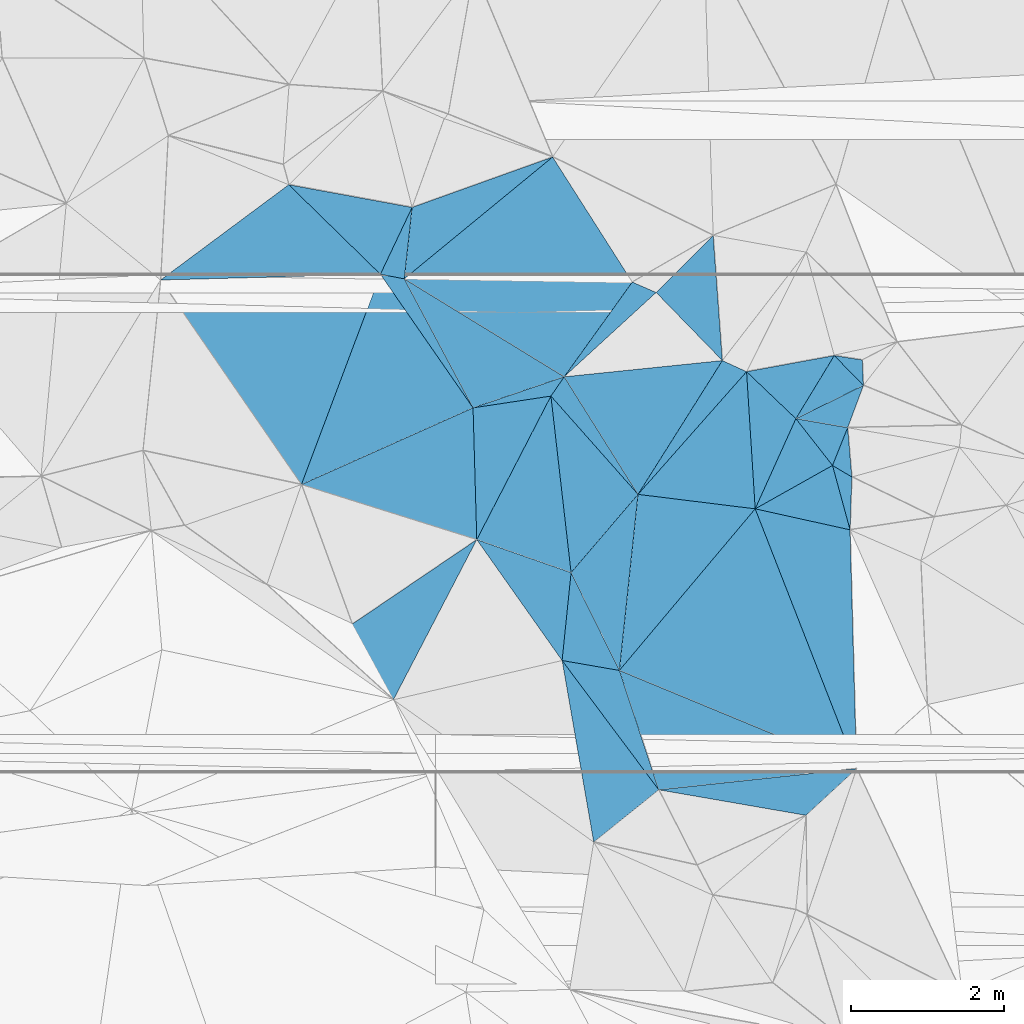
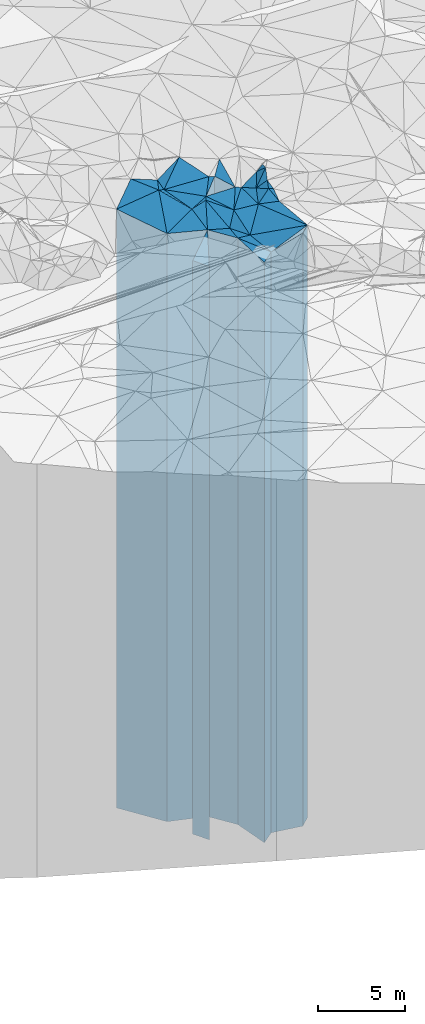
# One storey, part 205 of 275: 42 plates.
"""IFC2X3 building model written with IfcOpenShell, lengths in millimetres."""

from ifc_helpers import new_model, si_unit, frame, origin_with_axes, place, context, subcontext, project, spatial, faceted_brep, material, type_object, element, save


model = new_model("IFC2X3")

# Units and contexts
model_context = context("Model", 3, precision=1e-05, world=origin_with_axes())
body_context = subcontext(model_context, "Body", "Model", "MODEL_VIEW")
ifc_project = project(units=[si_unit("LENGTHUNIT", "METRE", prefix="MILLI"), si_unit("AREAUNIT", "SQUARE_METRE"), si_unit("VOLUMEUNIT", "CUBIC_METRE"), si_unit("MASSUNIT", "GRAM", prefix="KILO"), si_unit("TIMEUNIT", "SECOND"), si_unit("PLANEANGLEUNIT", "RADIAN"), si_unit("SOLIDANGLEUNIT", "STERADIAN"), si_unit("THERMODYNAMICTEMPERATUREUNIT", "DEGREE_CELSIUS"), si_unit("LUMINOUSINTENSITYUNIT", "LUMEN")], contexts=[model_context])

# Site, building, storey
site_placement = place(None, origin_with_axes())
site = spatial("IfcSite", under=ifc_project, at=site_placement, CompositionType="ELEMENT")
building_placement = place(site_placement, origin_with_axes())
building = spatial("IfcBuilding", under=site, at=building_placement, Name="Undefined", CompositionType="ELEMENT")
storey_placement = place(building_placement, origin_with_axes())
storey = spatial("IfcBuildingStorey", under=building, at=storey_placement, Name="Undefined", CompositionType="ELEMENT", Elevation=0.0)

# Plates
ifc_material = material()
plate_type_1 = type_object("IfcPlateType", PredefinedType="NOTDEFINED")
plate_1_placement = place(storey_placement, frame((-119183.131620389, 61506.4267955561, 28304.0), z_axis=(0.985184457035892, 0.171498063006248, 0.0), x_axis=(0.171498063006245, -0.985184457035892, 0.0)))
element("IfcPlate", 1, at=plate_1_placement, inside=storey, type_object=plate_type_1, material=ifc_material, Name="00", context=body_context, shape_type="Brep", body=[
    faceted_brep([(0.0, -20916.0, 0.0), (1875.76220703125, -20516.0, 951.270812988281), (1875.76220703125, 20476.0, 951.270812988281), (0.0, 20476.0, 0.0), (2401.10400390624, -20476.0, -1.12049747258425e-09), (2401.10400390624, 20476.0, -1.12049747258425e-09)], [[[0, 1, 2, 3]], [[1, 4, 5, 2]], [[4, 0, 3, 5]], [[5, 3, 2]], [[4, 1, 0]]]),
])
plate_type_2 = type_object("IfcPlateType", PredefinedType="NOTDEFINED")
plate_2_placement = place(storey_placement, frame((-117924.26484308, 59821.5961105942, 28324.0), z_axis=(-0.949714789561754, -0.313116301855515, 0.0), x_axis=(-0.313116301855509, 0.949714789561756, 0.0)))
element("IfcPlate", 2, at=plate_2_placement, inside=storey, type_object=plate_type_2, material=ifc_material, Name="00", context=body_context, shape_type="Brep", body=[
    faceted_brep([(2.91038304567337e-11, -20496.0, 2.91038304567337e-11), (1994.28027343753, -20896.0, 668.016418457046), (1994.28027343753, 20496.0, 668.016418457046), (2.91038304567337e-11, 20496.0, 2.91038304567337e-11), (1637.83398437503, -20916.0, -3.28873284161091e-09), (1637.83398437503, 20496.0, -3.28873284161091e-09)], [[[0, 1, 2, 3]], [[1, 4, 5, 2]], [[4, 0, 3, 5]], [[5, 3, 2]], [[4, 1, 0]]]),
])
plate_type_3 = type_object("IfcPlateType", PredefinedType="NOTDEFINED")
plate_3_placement = place(storey_placement, frame((-119183.131620389, 61506.4267955561, 28499.0), z_axis=(0.170841814937065, 0.985298469636998, 0.0), x_axis=(0.985298469637004, -0.17084181493703, 0.0)))
element("IfcPlate", 3, at=plate_3_placement, inside=storey, type_object=plate_type_3, material=ifc_material, Name="00", context=body_context, shape_type="Brep", body=[
    faceted_brep([(1.45519152283669e-11, -20721.0, 0.0), (-80.431526184082, -20671.0, 1148.22937011719), (-80.431526184082, 20671.0, 1148.22937011719), (1.45519152283669e-11, 20671.0, 0.0), (757.16577148439, -20741.0, -2.895831130445e-09), (757.16577148439, 20671.0, -2.895831130445e-09)], [[[0, 1, 2, 3]], [[1, 4, 5, 2]], [[4, 0, 3, 5]], [[5, 3, 2]], [[4, 1, 0]]]),
])
plate_type_4 = type_object("IfcPlateType", PredefinedType="NOTDEFINED")
plate_4_placement = place(storey_placement, frame((-118194.118442681, 63671.2946747395, 28499.0), z_axis=(0.759992196008356, -0.649932198007143, 0.0), x_axis=(-0.649932198007148, -0.759992196008352, 0.0)))
element("IfcPlate", 4, at=plate_4_placement, inside=storey, type_object=plate_type_4, material=ifc_material, Name="00", context=body_context, shape_type="Brep", body=[
    faceted_brep([(-7.27595761418343e-12, -21041.0, -2.91038304567337e-11), (1901.51171875001, -20741.0, 1306.42761230466), (1901.51171875001, 20671.0, 1306.42761230466), (1.45519152283669e-11, 20671.0, 0.0), (1341.82714843749, -20671.0, 1.45519152283669e-10), (1341.82714843749, 20671.0, 1.45519152283669e-10)], [[[0, 1, 2, 3]], [[1, 4, 5, 2]], [[4, 0, 3, 5]], [[5, 3, 2]], [[4, 1, 0]]]),
])
plate_type_5 = type_object("IfcPlateType", PredefinedType="NOTDEFINED")
plate_5_placement = place(storey_placement, frame((-115345.769629533, 60097.9336464306, 28324.0), z_axis=(-0.382343494971792, -0.924020265931844, 0.0), x_axis=(-0.924020265931842, 0.382343494971797, 0.0)))
element("IfcPlate", 5, at=plate_5_placement, inside=storey, type_object=plate_type_5, material=ifc_material, Name="00", context=body_context, shape_type="Brep", body=[
    faceted_brep([(0.0, -21316.0, -7.27595761418343e-12), (2276.92602539064, -20496.0, 1241.21240234374), (2276.92602539064, 20496.0, 1241.21240234374), (2.91038304567337e-11, 20496.0, 2.91038304567337e-11), (3345.51928710939, -20916.0, 6.91943569108844e-09), (3345.51928710939, 20496.0, 6.91943569108844e-09)], [[[0, 1, 2, 3]], [[1, 4, 5, 2]], [[4, 0, 3, 5]], [[5, 3, 2]], [[4, 1, 0]]]),
])
plate_type_6 = type_object("IfcPlateType", PredefinedType="NOTDEFINED")
plate_6_placement = place(storey_placement, frame((-118437.09734801, 61377.0712218987, 28534.0), z_axis=(-0.765511761828982, 0.643421900856264, 0.0), x_axis=(0.643421900856258, 0.765511761828987, 0.0)))
element("IfcPlate", 6, at=plate_6_placement, inside=storey, type_object=plate_type_6, material=ifc_material, Name="00", context=body_context, shape_type="Brep", body=[
    faceted_brep([(-7.27595761418343e-12, -20706.0, -1.45519152283669e-11), (1912.59301757814, -21006.0, 1290.150390625), (1912.59301757814, 20706.0, 1290.150390625), (2.18278728425503e-11, 20706.0, 0.0), (2750.45458984377, -21006.0, 3.47790773957968e-09), (2750.45458984377, 20706.0, 3.47790773957968e-09)], [[[0, 1, 2, 3]], [[1, 4, 5, 2]], [[4, 0, 3, 5]], [[5, 3, 2]], [[4, 1, 0]]]),
])
plate_type_7 = type_object("IfcPlateType", PredefinedType="NOTDEFINED")
plate_7_placement = place(storey_placement, frame((-119328.867979049, 64951.7803207788, 28499.0), z_axis=(0.888482110108516, -0.45891125505605, 0.0), x_axis=(-0.458911255056047, -0.888482110108517, 0.0)))
element("IfcPlate", 7, at=plate_7_placement, inside=storey, type_object=plate_type_7, material=ifc_material, Name="00", context=body_context, shape_type="Brep", body=[
    faceted_brep([(0.0, -21351.0, 0.0), (1923.20886230468, -20671.0, 1288.97937011722), (1923.20886230468, 20671.0, 1288.97937011722), (1.45519152283669e-11, 20671.0, 0.0), (2105.23168945311, -20731.0, 9.19681042432785e-09), (2105.23168945311, 20671.0, 9.19681042432785e-09)], [[[0, 1, 2, 3]], [[1, 4, 5, 2]], [[4, 0, 3, 5]], [[5, 3, 2]], [[4, 1, 0]]]),
])
plate_type_8 = type_object("IfcPlateType", PredefinedType="NOTDEFINED")
plate_8_placement = place(storey_placement, frame((-115462.191569399, 64540.3030515924, 28874.0), z_axis=(0.927767243245815, -0.373159406098871, 0.0), x_axis=(-0.373159406098872, -0.927767243245814, 0.0)))
element("IfcPlate", 8, at=plate_8_placement, inside=storey, type_object=plate_type_8, material=ifc_material, Name="00", context=body_context, shape_type="Brep", body=[
    faceted_brep([(3.63797880709171e-12, -21286.0, 0.0), (576.005126953121, -21046.0, 290.547912597642), (576.005126953121, 21046.0, 290.547912597642), (3.63797880709171e-12, 21046.0, 0.0), (530.377197265621, -21066.0, 1.94995664060116e-09), (530.377197265621, 21046.0, 1.94995664060116e-09)], [[[0, 1, 2, 3]], [[1, 4, 5, 2]], [[4, 0, 3, 5]], [[5, 3, 2]], [[4, 1, 0]]]),
])
plate_type_9 = type_object("IfcPlateType", PredefinedType="NOTDEFINED")
plate_9_placement = place(storey_placement, frame((-115407.572455855, 63897.4836738231, 28649.0), z_axis=(-0.512574769797824, -0.858642594661311, 0.0), x_axis=(-0.858642594661316, 0.512574769797815, 0.0)))
element("IfcPlate", 9, at=plate_9_placement, inside=storey, type_object=plate_type_9, material=ifc_material, Name="00", context=body_context, shape_type="Brep", body=[
    faceted_brep([(0.0, -21271.0, 7.27595761418343e-12), (-332.529968261719, -20821.0, 603.178100585945), (-332.529968261719, 20821.0, 603.178100585945), (0.0, 20821.0, 7.27595761418343e-12), (294.108825683594, -21291.0, -1.50612322613597e-09), (294.108825683594, 20821.0, -1.50612322613597e-09)], [[[0, 1, 2, 3]], [[1, 4, 5, 2]], [[4, 0, 3, 5]], [[5, 3, 2]], [[4, 1, 0]]]),
])
plate_type_10 = type_object("IfcPlateType", PredefinedType="NOTDEFINED")
plate_10_placement = place(storey_placement, frame((-119155.779576503, 65203.2567707775, 28749.0), z_axis=(-0.522218806266238, -0.852811537434775, 0.0), x_axis=(-0.852811537434775, 0.522218806266238, 0.0)))
element("IfcPlate", 10, at=plate_10_placement, inside=storey, type_object=plate_type_10, material=ifc_material, Name="00", context=body_context, shape_type="Brep", body=[
    faceted_brep([(0.0, -21161.0, 2.72848410531878e-12), (801.453979492188, -20921.0, 965.542114257808), (801.453979492188, 20921.0, 965.542114257808), (0.0, 20921.0, 2.72848410531878e-12), (2443.80859375, -21591.0, 1.97451299754903e-09), (2443.80859375, 20921.0, 1.97451299754903e-09)], [[[0, 1, 2, 3]], [[1, 4, 5, 2]], [[4, 0, 3, 5]], [[5, 3, 2]], [[4, 1, 0]]]),
])
plate_type_11 = type_object("IfcPlateType", PredefinedType="NOTDEFINED")
plate_11_placement = place(storey_placement, frame((-121550.470798273, 66538.9415960164, 28579.0), z_axis=(0.936101686798957, -0.351729486924464, 0.0), x_axis=(-0.351729486924462, -0.936101686798958, 0.0)))
element("IfcPlate", 11, at=plate_11_placement, inside=storey, type_object=plate_type_11, material=ifc_material, Name="00", context=body_context, shape_type="Brep", body=[
    faceted_brep([(0.0, -21801.0, 0.0), (1204.82641601563, -21091.0, 1742.06579589844), (1204.82641601563, 20751.0, 1742.06579589844), (0.0, 20751.0, 0.0), (2927.55859375, -20751.0, 2.09547579288483e-08), (2927.55859375, 20751.0, 2.09547579288483e-08)], [[[0, 1, 2, 3]], [[1, 4, 5, 2]], [[4, 0, 3, 5]], [[5, 3, 2]], [[4, 1, 0]]]),
])
plate_type_12 = type_object("IfcPlateType", PredefinedType="NOTDEFINED")
plate_12_placement = place(storey_placement, frame((-119155.779576503, 65203.2567707775, 28869.0), z_axis=(-0.812080748612463, 0.583545077721526, 0.0), x_axis=(0.583545077721523, 0.812080748612465, 0.0)))
element("IfcPlate", 12, at=plate_12_placement, inside=storey, type_object=plate_type_12, material=ifc_material, Name="00", context=body_context, shape_type="Brep", body=[
    faceted_brep([(-7.27595761418343e-12, -21041.0, -2.91038304567337e-11), (-179.791320800774, -21471.0, 2437.18579101563), (-179.791320800774, 21041.0, 2437.18579101563), (2.18278728425503e-11, 21041.0, 0.0), (1519.53942871095, -21371.0, -2.3283064365387e-10), (1519.53942871095, 21041.0, -2.3283064365387e-10)], [[[0, 1, 2, 3]], [[1, 4, 5, 2]], [[4, 0, 3, 5]], [[5, 3, 2]], [[4, 1, 0]]]),
])
plate_type_13 = type_object("IfcPlateType", PredefinedType="NOTDEFINED")
plate_13_placement = place(storey_placement, frame((-120343.493003675, 64798.3656558902, 28749.0), z_axis=(-0.149503958020634, 0.988761127136461, 0.0), x_axis=(0.988761127136461, 0.149503958020635, 0.0)))
element("IfcPlate", 13, at=plate_13_placement, inside=storey, type_object=plate_type_13, material=ifc_material, Name="00", context=body_context, shape_type="Brep", body=[
    faceted_brep([(0.0, -20921.0, 0.0), (1234.89770507814, -21161.0, 222.772735595703), (1234.89770507814, 20921.0, 222.772735595703), (0.0, 20921.0, 2.72848410531878e-12), (1026.15783691408, -21101.0, 1.76078174263239e-09), (1026.15783691408, 20921.0, 1.76078174263239e-09)], [[[0, 1, 2, 3]], [[1, 4, 5, 2]], [[4, 0, 3, 5]], [[5, 3, 2]], [[4, 1, 0]]]),
])
plate_type_14 = type_object("IfcPlateType", PredefinedType="NOTDEFINED")
plate_14_placement = place(storey_placement, frame((-115637.071651429, 65479.8332304102, 28749.0), z_axis=(0.180778557086176, -0.983523824468854, 0.0), x_axis=(-0.983523824468853, -0.180778557086182, 0.0)))
element("IfcPlate", 14, at=plate_14_placement, inside=storey, type_object=plate_type_14, material=ifc_material, Name="00", context=body_context, shape_type="Brep", body=[
    faceted_brep([(0.0, -21501.0, -1.45519152283669e-11), (640.552856445313, -21011.0, 718.534667968721), (640.552856445313, 20921.0, 718.534667968721), (0.0, 20921.0, 2.72848410531878e-12), (1161.80895996095, -20921.0, 3.41970007866621e-09), (1161.80895996095, 20921.0, 3.41970007866621e-09)], [[[0, 1, 2, 3]], [[1, 4, 5, 2]], [[4, 0, 3, 5]], [[5, 3, 2]], [[4, 1, 0]]]),
])
plate_type_15 = type_object("IfcPlateType", PredefinedType="NOTDEFINED")
plate_15_placement = place(storey_placement, frame((-116667.39467936, 63482.5764972598, 28684.0), z_axis=(-0.489643351877605, 0.871922810782046, 0.0), x_axis=(0.871922810782047, 0.489643351877604, 0.0)))
element("IfcPlate", 15, at=plate_15_placement, inside=storey, type_object=plate_type_15, material=ifc_material, Name="00", context=body_context, shape_type="Brep", body=[
    faceted_brep([(-1.45519152283669e-11, -20856.0, 0.0), (1037.52539062499, -21076.0, 764.683715820313), (1037.52539062499, 20856.0, 764.683715820313), (-1.45519152283669e-11, 20856.0, 0.0), (1155.24890136719, -21256.0, -2.8521753847599e-09), (1155.24890136719, 20856.0, -2.8521753847599e-09)], [[[0, 1, 2, 3]], [[1, 4, 5, 2]], [[4, 0, 3, 5]], [[5, 3, 2]], [[4, 1, 0]]]),
])
plate_type_16 = type_object("IfcPlateType", PredefinedType="NOTDEFINED")
plate_16_placement = place(storey_placement, frame((-116137.174958694, 64657.3390468063, 28794.0), z_axis=(0.787267103683257, 0.616612120751916, 0.0), x_axis=(0.616612120751918, -0.787267103683255, 0.0)))
element("IfcPlate", 16, at=plate_16_placement, inside=storey, type_object=plate_type_16, material=ifc_material, Name="00", context=body_context, shape_type="Brep", body=[
    faceted_brep([(2.91038304567337e-11, -20966.0, 1.45519152283669e-11), (508.341522216797, -21366.0, 459.226409912117), (508.341522216797, 20966.0, 459.226409912117), (2.91038304567337e-11, 20966.0, 1.45519152283669e-11), (773.692443847656, -21146.0, 1.5788828022778e-09), (773.692443847656, 20966.0, 1.5788828022778e-09)], [[[0, 1, 2, 3]], [[1, 4, 5, 2]], [[4, 0, 3, 5]], [[5, 3, 2]], [[4, 1, 0]]]),
])
plate_type_17 = type_object("IfcPlateType", PredefinedType="NOTDEFINED")
plate_17_placement = place(storey_placement, frame((-121137.59422499, 67410.3387128543, 29104.0), z_axis=(-0.180869426929462, -0.983507117616445, 0.0), x_axis=(-0.983507117616445, 0.180869426929464, 0.0)))
element("IfcPlate", 17, at=plate_17_placement, inside=storey, type_object=plate_type_17, material=ifc_material, Name="00", context=body_context, shape_type="Brep", body=[
    faceted_brep([(0.0, -21316.0, -7.27595761418343e-12), (248.457946777344, -21276.0, 931.70202636718), (248.457946777344, 21276.0, 931.70202636718), (0.0, 21276.0, 0.0), (1633.67687988281, -21776.0, -1.25583028420806e-08), (1633.67687988281, 21276.0, -1.25583028420806e-08)], [[[0, 1, 2, 3]], [[1, 4, 5, 2]], [[4, 0, 3, 5]], [[5, 3, 2]], [[4, 1, 0]]]),
])
plate_type_18 = type_object("IfcPlateType", PredefinedType="NOTDEFINED")
plate_18_placement = place(storey_placement, frame((-120343.493003675, 64798.3656558902, 28749.0), z_axis=(-0.882394073417891, -0.470511104222824, 0.0), x_axis=(-0.470511104222825, 0.882394073417891, 0.0)))
element("IfcPlate", 18, at=plate_18_placement, inside=storey, type_object=plate_type_18, material=ifc_material, Name="00", context=body_context, shape_type="Brep", body=[
    faceted_brep([(0.0, -20921.0, 0.0), (2103.77026367188, -21631.0, 246.069747924819), (2103.77026367188, 20921.0, 246.069747924819), (0.0, 20921.0, 2.72848410531878e-12), (1905.15087890625, -21591.0, 3.36149241775274e-09), (1905.15087890625, 20921.0, 3.36149241775274e-09)], [[[0, 1, 2, 3]], [[1, 4, 5, 2]], [[4, 0, 3, 5]], [[5, 3, 2]], [[4, 1, 0]]]),
])
plate_type_19 = type_object("IfcPlateType", PredefinedType="NOTDEFINED")
plate_19_placement = place(storey_placement, frame((-120294.982445827, 63081.3197258764, 28529.0), z_axis=(-0.888482110108516, 0.45891125505605, 0.0), x_axis=(0.458911255056051, 0.888482110108515, 0.0)))
element("IfcPlate", 19, at=plate_19_placement, inside=storey, type_object=plate_type_19, material=ifc_material, Name="00", context=body_context, shape_type="Brep", body=[
    faceted_brep([(9.54969436861575e-12, -20701.0, 0.0), (1503.30249023438, -21141.0, 831.072448730469), (1503.30249023438, 20701.0, 831.072448730469), (9.54969436861575e-12, 20701.0, 0.0), (2105.23168945313, -21321.0, 9.13860276341438e-09), (2105.23168945313, 20701.0, 9.13860276341438e-09)], [[[0, 1, 2, 3]], [[1, 4, 5, 2]], [[4, 0, 3, 5]], [[5, 3, 2]], [[4, 1, 0]]]),
])
plate_type_20 = type_object("IfcPlateType", PredefinedType="NOTDEFINED")
plate_20_placement = place(storey_placement, frame((-115257.058617225, 65090.2307485966, 29039.0), z_axis=(-0.998896409609664, -0.0469676789816477, 0.0), x_axis=(-0.0469676789816322, 0.998896409609664, 0.0)))
element("IfcPlate", 20, at=plate_20_placement, inside=storey, type_object=plate_type_20, material=ifc_material, Name="00", context=body_context, shape_type="Brep", body=[
    faceted_brep([(0.0, -21611.0, 1.45519152283669e-11), (407.020843505859, -21211.0, 361.294921875015), (407.020843505859, 21211.0, 361.294921875015), (0.0, 21211.0, 1.45519152283669e-11), (332.415405273438, -21641.0, 7.27595761418343e-11), (332.415405273438, 21211.0, 7.27595761418343e-11)], [[[0, 1, 2, 3]], [[1, 4, 5, 2]], [[4, 0, 3, 5]], [[5, 3, 2]], [[4, 1, 0]]]),
])
plate_type_21 = type_object("IfcPlateType", PredefinedType="NOTDEFINED")
plate_21_placement = place(storey_placement, frame((-116137.174958694, 64657.3390468063, 28794.0), z_axis=(0.170841814937065, 0.985298469636998, 0.0), x_axis=(0.985298469637004, -0.17084181493703, 0.0)))
element("IfcPlate", 21, at=plate_21_placement, inside=storey, type_object=plate_type_21, material=ifc_material, Name="00", context=body_context, shape_type="Brep", body=[
    faceted_brep([(2.91038304567337e-11, -20966.0, 1.45519152283669e-11), (793.221252441406, -21856.0, 576.888183593757), (793.221252441406, 20966.0, 576.888183593757), (2.91038304567337e-11, 20966.0, 1.45519152283669e-11), (685.054748535156, -21366.0, -2.60479282587767e-09), (685.054748535156, 20966.0, -2.60479282587767e-09)], [[[0, 1, 2, 3]], [[1, 4, 5, 2]], [[4, 0, 3, 5]], [[5, 3, 2]], [[4, 1, 0]]]),
])
plate_type_22 = type_object("IfcPlateType", PredefinedType="NOTDEFINED")
plate_22_placement = place(storey_placement, frame((-121550.470798273, 66538.9415960164, 29084.0), z_axis=(0.188098807986449, 0.98215010992927, 0.0), x_axis=(0.982150109929266, -0.188098807986467, 0.0)))
element("IfcPlate", 22, at=plate_22_placement, inside=storey, type_object=plate_type_22, material=ifc_material, Name="00", context=body_context, shape_type="Brep", body=[
    faceted_brep([(0.0, -21296.0, 1.45519152283669e-11), (241.598007202178, -21336.0, 933.504394531265), (241.598007202178, 21256.0, 933.504394531265), (0.0, 21256.0, 1.45519152283669e-11), (316.227752685547, -21256.0, 1.67347025126219e-09), (316.227752685547, 21256.0, 1.67347025126219e-09)], [[[0, 1, 2, 3]], [[1, 4, 5, 2]], [[4, 0, 3, 5]], [[5, 3, 2]], [[4, 1, 0]]]),
])
plate_type_23 = type_object("IfcPlateType", PredefinedType="NOTDEFINED")
plate_23_placement = place(storey_placement, frame((-117957.606478742, 66301.6106426251, 28869.0), z_axis=(-0.399271495028854, -0.91683274006627, 0.0), x_axis=(-0.916832740066265, 0.399271495028864, 0.0)))
element("IfcPlate", 23, at=plate_23_placement, inside=storey, type_object=plate_type_23, material=ifc_material, Name="00", context=body_context, shape_type="Brep", body=[
    faceted_brep([(-6.59383658785373e-12, -21371.0, 1.45519152283669e-11), (659.982910156279, -21041.0, 1485.40319824219), (659.982910156279, 21041.0, 1485.40319824219), (2.18278728425503e-11, 21041.0, 0.0), (339.705749511719, -21371.0, 2.37923813983798e-09), (339.705749511719, 21041.0, 2.37923813983798e-09)], [[[0, 1, 2, 3]], [[1, 4, 5, 2]], [[4, 0, 3, 5]], [[5, 3, 2]], [[4, 1, 0]]]),
])
plate_type_24 = type_object("IfcPlateType", PredefinedType="NOTDEFINED")
plate_24_placement = place(storey_placement, frame((-121239.887663094, 66479.4595302959, 29034.0), z_axis=(0.0142080939991206, 0.999899059938008, 0.0), x_axis=(0.999899059938008, -0.0142080939991182, 0.0)))
element("IfcPlate", 24, at=plate_24_placement, inside=storey, type_object=plate_type_24, material=ifc_material, Name="00", context=body_context, shape_type="Brep", body=[
    faceted_brep([(1.45519152283669e-11, -21306.0, 3.63797880709171e-12), (1910.45300292969, -21956.0, 1614.67309570312), (1910.45300292969, 21206.0, 1614.67309570312), (-1.45519152283669e-11, 21206.0, 0.0), (2971.12768554688, -21206.0, -1.64582161232829e-08), (2971.12768554688, 21206.0, -1.64582161232829e-08)], [[[0, 1, 2, 3]], [[1, 4, 5, 2]], [[4, 0, 3, 5]], [[5, 3, 2]], [[4, 1, 0]]]),
])
plate_type_25 = type_object("IfcPlateType", PredefinedType="NOTDEFINED")
plate_25_placement = place(storey_placement, frame((-117214.984869905, 67045.4608601347, 28769.0), z_axis=(0.70769098215803, -0.706522097157763, 0.0), x_axis=(-0.706522097157767, -0.707690982158026, 0.0)))
element("IfcPlate", 25, at=plate_25_placement, inside=storey, type_object=plate_type_25, material=ifc_material, Name="00", context=body_context, shape_type="Brep", body=[
    faceted_brep([(7.27595761418343e-12, -21981.0, 0.0), (1069.5516357422, -20941.0, 1236.99609374999), (1069.5516357422, 20941.0, 1236.99609374999), (7.27595761418343e-12, 20941.0, 0.0), (1051.0947265625, -21471.0, -1.16415321826935e-09), (1051.0947265625, 20941.0, -1.16415321826935e-09)], [[[0, 1, 2, 3]], [[1, 4, 5, 2]], [[4, 0, 3, 5]], [[5, 3, 2]], [[4, 1, 0]]]),
])
plate_type_26 = type_object("IfcPlateType", PredefinedType="NOTDEFINED")
plate_26_placement = place(storey_placement, frame((-122580.179521868, 63798.448949693, 28579.0), z_axis=(-0.93610168679896, 0.351729486924458, 0.0), x_axis=(0.351729486924463, 0.936101686798958, 0.0)))
element("IfcPlate", 26, at=plate_26_placement, inside=storey, type_object=plate_type_26, material=ifc_material, Name="00", context=body_context, shape_type="Brep", body=[
    faceted_brep([(0.0, -20751.0, 2.91038304567337e-11), (1850.0739746094, -21501.0, 2655.11328125003), (1850.0739746094, 20751.0, 2655.11328125003), (0.0, 20751.0, 0.0), (2927.55859374999, -21801.0, 1.07684172689915e-09), (2927.55859375, 20751.0, 2.09547579288483e-08)], [[[0, 1, 2, 3]], [[1, 4, 5, 2]], [[4, 0, 3, 5]], [[5, 3, 2]], [[4, 1, 0]]]),
])
plate_type_27 = type_object("IfcPlateType", PredefinedType="NOTDEFINED")
plate_27_placement = place(storey_placement, frame((-118194.118442681, 63671.2946747395, 28684.0), z_axis=(-0.748923343859627, 0.662656641875802, 0.0), x_axis=(0.662656641875801, 0.748923343859628, 0.0)))
element("IfcPlate", 27, at=plate_27_placement, inside=storey, type_object=plate_type_27, material=ifc_material, Name="00", context=body_context, shape_type="Brep", body=[
    faceted_brep([(-1.45519152283669e-11, -20856.0, 0.0), (2033.77185058595, -21026.0, 332.223175048828), (2033.77185058595, 20856.0, 332.223175048828), (-1.45519152283669e-11, 20856.0, 0.0), (2134.40869140625, -20986.0, 4.39467839896679e-09), (2134.40869140625, 20856.0, 4.39467839896679e-09)], [[[0, 1, 2, 3]], [[1, 4, 5, 2]], [[4, 0, 3, 5]], [[5, 3, 2]], [[4, 1, 0]]]),
])
plate_type_28 = type_object("IfcPlateType", PredefinedType="NOTDEFINED")
plate_28_placement = place(storey_placement, frame((-118194.118442681, 63671.2946747395, 28684.0), z_axis=(-0.845957862385681, 0.533249749243119, 0.0), x_axis=(0.533249749243116, 0.845957862385683, 0.0)))
element("IfcPlate", 28, at=plate_28_placement, inside=storey, type_object=plate_type_28, material=ifc_material, Name="00", context=body_context, shape_type="Brep", body=[
    faceted_brep([(-1.45519152283669e-11, -20856.0, 0.0), (783.169799804678, -21226.0, 1630.44323730472), (783.169799804678, 20856.0, 1630.44323730472), (-1.45519152283669e-11, 20856.0, 0.0), (2060.72802734375, -21026.0, -7.36326910555363e-09), (2060.72802734375, 20856.0, -7.36326910555363e-09)], [[[0, 1, 2, 3]], [[1, 4, 5, 2]], [[4, 0, 3, 5]], [[5, 3, 2]], [[4, 1, 0]]]),
])
plate_type_29 = type_object("IfcPlateType", PredefinedType="NOTDEFINED")
plate_29_placement = place(storey_placement, frame((-119306.686039508, 68066.8257396384, 29084.0), z_axis=(0.337517657096617, -0.941319197269454, 0.0), x_axis=(-0.941319197269456, -0.337517657096613, 0.0)))
element("IfcPlate", 29, at=plate_29_placement, inside=storey, type_object=plate_type_29, material=ifc_material, Name="00", context=body_context, shape_type="Brep", body=[
    faceted_brep([(0.0, -21906.0, -2.91038304567337e-11), (2355.52392578126, -21256.0, 841.728576660142), (2355.52392578126, 21256.0, 841.728576660142), (0.0, 21256.0, 1.45519152283669e-11), (1945.04504394533, -21336.0, 6.79574441164732e-09), (1945.04504394533, 21256.0, 6.79574441164732e-09)], [[[0, 1, 2, 3]], [[1, 4, 5, 2]], [[4, 0, 3, 5]], [[5, 3, 2]], [[4, 1, 0]]]),
])
plate_type_30 = type_object("IfcPlateType", PredefinedType="NOTDEFINED")
plate_30_placement = place(storey_placement, frame((-116667.39467936, 63482.5764972598, 28649.0), z_axis=(0.215988483974284, 0.976395910883741, 0.0), x_axis=(0.976395910883742, -0.21598848397428, 0.0)))
element("IfcPlate", 30, at=plate_30_placement, inside=storey, type_object=plate_type_30, material=ifc_material, Name="00", context=body_context, shape_type="Brep", body=[
    faceted_brep([(0.0, -20891.0, 1.45519152283669e-11), (861.335693359375, -21291.0, 769.87060546875), (861.335693359375, 20821.0, 769.87060546875), (0.0, 20821.0, 7.27595761418343e-12), (1266.05688476563, -20821.0, 1.28056854009628e-09), (1266.05688476563, 20821.0, 1.28056854009628e-09)], [[[0, 1, 2, 3]], [[1, 4, 5, 2]], [[4, 0, 3, 5]], [[5, 3, 2]], [[4, 1, 0]]]),
])
plate_type_31 = type_object("IfcPlateType", PredefinedType="NOTDEFINED")
plate_31_placement = place(storey_placement, frame((-119066.215087073, 62651.5165406143, 28499.0), z_axis=(-0.759992196008356, 0.649932198007143, 0.0), x_axis=(0.649932198007148, 0.759992196008352, 0.0)))
element("IfcPlate", 31, at=plate_31_placement, inside=storey, type_object=plate_type_31, material=ifc_material, Name="00", context=body_context, shape_type="Brep", body=[
    faceted_brep([(1.45519152283669e-11, -20671.0, 5.45696821063757e-12), (1577.47595214847, -21351.0, 1694.62963867188), (1577.47595214847, 20671.0, 1694.62963867188), (1.45519152283669e-11, 20671.0, 0.0), (1341.8271484375, -21041.0, 2.03726813197136e-10), (1341.82714843749, 20671.0, 1.45519152283669e-10)], [[[0, 1, 2, 3]], [[1, 4, 5, 2]], [[4, 0, 3, 5]], [[5, 3, 2]], [[4, 1, 0]]]),
])
plate_type_32 = type_object("IfcPlateType", PredefinedType="NOTDEFINED")
plate_32_placement = place(storey_placement, frame((-116137.174958694, 64657.3390468063, 28684.0), z_axis=(-0.689949789235723, -0.723857229247302, 0.0), x_axis=(-0.723857229247305, 0.68994978923572, 0.0)))
element("IfcPlate", 32, at=plate_32_placement, inside=storey, type_object=plate_type_32, material=ifc_material, Name="00", context=body_context, shape_type="Brep", body=[
    faceted_brep([(3.63797880709171e-12, -21076.0, 1.45519152283669e-11), (-426.723785400376, -20856.0, 1216.18530273437), (-426.723785400376, 20856.0, 1216.18530273437), (-1.45519152283669e-11, 20856.0, 0.0), (887.693664550796, -20986.0, -2.64844857156277e-09), (887.693664550796, 20856.0, -2.64844857156277e-09)], [[[0, 1, 2, 3]], [[1, 4, 5, 2]], [[4, 0, 3, 5]], [[5, 3, 2]], [[4, 1, 0]]]),
])
plate_type_33 = type_object("IfcPlateType", PredefinedType="NOTDEFINED")
plate_33_placement = place(storey_placement, frame((-115257.058617225, 65090.2307485966, 28794.0), z_axis=(-0.715861798912104, -0.698241995914258, 0.0), x_axis=(-0.698241995914264, 0.715861798912098, 0.0)))
element("IfcPlate", 33, at=plate_33_placement, inside=storey, type_object=plate_type_33, material=ifc_material, Name="00", context=body_context, shape_type="Brep", body=[
    faceted_brep([(-1.45519152283669e-11, -21856.0, 0.0), (304.6435546875, -20966.0, 932.304809570298), (304.6435546875, 20966.0, 932.304809570298), (2.91038304567337e-11, 20966.0, 1.45519152283669e-11), (544.242614746094, -21456.0, 2.03726813197136e-10), (544.242614746094, 20966.0, 2.03726813197136e-10)], [[[0, 1, 2, 3]], [[1, 4, 5, 2]], [[4, 0, 3, 5]], [[5, 3, 2]], [[4, 1, 0]]]),
])
plate_type_34 = type_object("IfcPlateType", PredefinedType="NOTDEFINED")
plate_34_placement = place(storey_placement, frame((-116779.738417821, 65269.8030873788, 28684.0), z_axis=(0.748923343859627, -0.662656641875802, 0.0), x_axis=(-0.662656641875799, -0.74892334385963, 0.0)))
element("IfcPlate", 34, at=plate_34_placement, inside=storey, type_object=plate_type_34, material=ifc_material, Name="00", context=body_context, shape_type="Brep", body=[
    faceted_brep([(-1.09139364212751e-11, -20986.0, 1.45519152283669e-11), (1264.05041503904, -20856.0, 1268.45446777344), (1264.05041503904, 20856.0, 1268.45446777344), (-1.45519152283669e-11, 20856.0, 0.0), (2134.40869140623, -20856.0, 4.43833414465189e-09), (2134.40869140625, 20856.0, 4.39467839896679e-09)], [[[0, 1, 2, 3]], [[1, 4, 5, 2]], [[4, 0, 3, 5]], [[5, 3, 2]], [[4, 1, 0]]]),
])
plate_type_35 = type_object("IfcPlateType", PredefinedType="NOTDEFINED")
plate_35_placement = place(storey_placement, frame((-115431.221927866, 63209.1227928358, 28649.0), z_axis=(-0.215988483974284, -0.976395910883741, 0.0), x_axis=(-0.976395910883741, 0.215988483974283, 0.0)))
element("IfcPlate", 35, at=plate_35_placement, inside=storey, type_object=plate_type_35, material=ifc_material, Name="00", context=body_context, shape_type="Brep", body=[
    faceted_brep([(-1.45519152283669e-11, -20821.0, 0.0), (-755.416320800796, -20991.0, 3019.29565429687), (-755.416320800796, 20821.0, 3019.29565429687), (0.0, 20821.0, 7.27595761418343e-12), (1266.05688476561, -20891.0, 1.2732925824821e-09), (1266.05688476563, 20821.0, 1.28056854009628e-09)], [[[0, 1, 2, 3]], [[1, 4, 5, 2]], [[4, 0, 3, 5]], [[5, 3, 2]], [[4, 1, 0]]]),
])
plate_type_36 = type_object("IfcPlateType", PredefinedType="NOTDEFINED")
plate_36_placement = place(storey_placement, frame((-120343.493003675, 64798.3656558902, 28529.0), z_axis=(0.408125868117541, -0.912925668262922, 0.0), x_axis=(-0.912925668262923, -0.40812586811754, 0.0)))
element("IfcPlate", 36, at=plate_36_placement, inside=storey, type_object=plate_type_36, material=ifc_material, Name="00", context=body_context, shape_type="Brep", body=[
    faceted_brep([(0.0, -21141.0, 0.0), (656.484313964844, -20701.0, 1587.33374023439), (656.484313964844, 20701.0, 1587.33374023439), (9.54969436861575e-12, 20701.0, 0.0), (2450.0205078125, -20801.0, -1.04046193882823e-08), (2450.0205078125, 20701.0, -1.04046193882823e-08)], [[[0, 1, 2, 3]], [[1, 4, 5, 2]], [[4, 0, 3, 5]], [[5, 3, 2]], [[4, 1, 0]]]),
])
plate_type_37 = type_object("IfcPlateType", PredefinedType="NOTDEFINED")
plate_37_placement = place(storey_placement, frame((-121550.470798273, 66538.9415960164, 28954.0), z_axis=(-0.698980799811061, -0.715140434806682, 0.0), x_axis=(-0.715140434806684, 0.698980799811059, 0.0)))
element("IfcPlate", 37, at=plate_37_placement, inside=storey, type_object=plate_type_37, material=ifc_material, Name="00", context=body_context, shape_type="Brep", body=[
    faceted_brep([(0.0, -21426.0, 0.0), (1996.2248535156, -21126.0, 2055.64746093749), (1996.2248535156, 21126.0, 2055.64746093749), (1.45519152283669e-11, 21126.0, -1.45519152283669e-11), (1669.40112304685, -21926.0, -9.56060830503702e-09), (1669.40112304685, 21126.0, -9.56060830503702e-09)], [[[0, 1, 2, 3]], [[1, 4, 5, 2]], [[4, 0, 3, 5]], [[5, 3, 2]], [[4, 1, 0]]]),
])
plate_type_38 = type_object("IfcPlateType", PredefinedType="NOTDEFINED")
plate_38_placement = place(storey_placement, frame((-121918.590619111, 61980.7305656333, 28051.0), z_axis=(0.877947640003972, 0.478756662002166, 0.0), x_axis=(0.478756662002171, -0.877947640003969, 0.0)))
element("IfcPlate", 38, at=plate_38_placement, inside=storey, type_object=plate_type_38, material=ifc_material, Name="00", context=body_context, shape_type="Brep", body=[
    faceted_brep([(0.0, -20249.0, 0.0), (-188.946426391631, -21179.0, 1952.35729980467), (-188.946426391631, 20223.0, 1952.35729980467), (0.0, 20223.0, 0.0), (1122.85791015624, -20223.0, -1.13504938781261e-09), (1122.85791015624, 20223.0, -1.13504938781261e-09)], [[[0, 1, 2, 3]], [[1, 4, 5, 2]], [[4, 0, 3, 5]], [[5, 3, 2]], [[4, 1, 0]]]),
])
plate_type_39 = type_object("IfcPlateType", PredefinedType="NOTDEFINED")
plate_39_placement = place(storey_placement, frame((-119155.779576503, 65203.2567707775, 28684.0), z_axis=(0.823738500097443, -0.566969914067065, 0.0), x_axis=(-0.566969914067059, -0.823738500097447, 0.0)))
element("IfcPlate", 39, at=plate_39_placement, inside=storey, type_object=plate_type_39, material=ifc_material, Name="00", context=body_context, shape_type="Brep", body=[
    faceted_brep([(1.45519152283669e-11, -21226.0, 1.45519152283669e-11), (716.7032470703, -20856.0, 1660.73376464841), (716.7032470703, 20856.0, 1660.73376464841), (-1.45519152283669e-11, 20856.0, 0.0), (305.286743164057, -21166.0, 2.03726813197136e-10), (305.286743164057, 20856.0, 2.03726813197136e-10)], [[[0, 1, 2, 3]], [[1, 4, 5, 2]], [[4, 0, 3, 5]], [[5, 3, 2]], [[4, 1, 0]]]),
])
plate_type_40 = type_object("IfcPlateType", PredefinedType="NOTDEFINED")
plate_40_placement = place(storey_placement, frame((-116005.890999821, 59488.967492618, 28324.0), z_axis=(-0.678053631958331, 0.735012429954838, 0.0), x_axis=(0.735012429954837, 0.678053631958333, 0.0)))
element("IfcPlate", 40, at=plate_40_placement, inside=storey, type_object=plate_type_40, material=ifc_material, Name="00", context=body_context, shape_type="Brep", body=[
    faceted_brep([(0.0, -21356.0, 0.0), (-1184.48852539063, -20496.0, 1545.24645996092), (-1184.48852539063, 20496.0, 1545.24645996092), (2.91038304567337e-11, 20496.0, 2.91038304567337e-11), (898.10913085939, -21316.0, -1.10594555735588e-09), (898.10913085939, 20496.0, -1.10594555735588e-09)], [[[0, 1, 2, 3]], [[1, 4, 5, 2]], [[4, 0, 3, 5]], [[5, 3, 2]], [[4, 1, 0]]]),
])
plate_type_41 = type_object("IfcPlateType", PredefinedType="NOTDEFINED")
plate_41_placement = place(storey_placement, frame((-119183.131620389, 61506.4267955561, 28499.0), z_axis=(-0.994827942804024, 0.10157442697999, 0.0), x_axis=(0.101574426979988, 0.994827942804024, 0.0)))
element("IfcPlate", 41, at=plate_41_placement, inside=storey, type_object=plate_type_41, material=ifc_material, Name="00", context=body_context, shape_type="Brep", body=[
    faceted_brep([(1.45519152283669e-11, -20721.0, 0.0), (1453.81188964844, -20731.0, 1266.06909179688), (1453.81188964844, 20671.0, 1266.06909179688), (1.45519152283669e-11, 20671.0, 0.0), (1151.04296875001, -20671.0, 1.07684172689915e-09), (1151.04296875001, 20671.0, 1.07684172689915e-09)], [[[0, 1, 2, 3]], [[1, 4, 5, 2]], [[4, 0, 3, 5]], [[5, 3, 2]], [[4, 1, 0]]]),
])
plate_type_42 = type_object("IfcPlateType", PredefinedType="NOTDEFINED")
plate_42_placement = place(storey_placement, frame((-118437.09734801, 61377.0712218987, 28534.0), z_axis=(0.382343494971792, 0.924020265931844, 0.0), x_axis=(0.924020265931841, -0.382343494971798, 0.0)))
element("IfcPlate", 42, at=plate_42_placement, inside=storey, type_object=plate_type_42, material=ifc_material, Name="00", context=body_context, shape_type="Brep", body=[
    faceted_brep([(-7.27595761418343e-12, -20706.0, -1.45519152283669e-11), (830.214904785156, -21006.0, 2622.16381835937), (830.214904785156, 20706.0, 2622.16381835937), (2.18278728425503e-11, 20706.0, 0.0), (3345.51928710936, -21106.0, 6.93216861691326e-09), (3345.51928710936, 20706.0, 6.93216861691326e-09)], [[[0, 1, 2, 3]], [[1, 4, 5, 2]], [[4, 0, 3, 5]], [[5, 3, 2]], [[4, 1, 0]]]),
])

save(model, "model.ifc")
